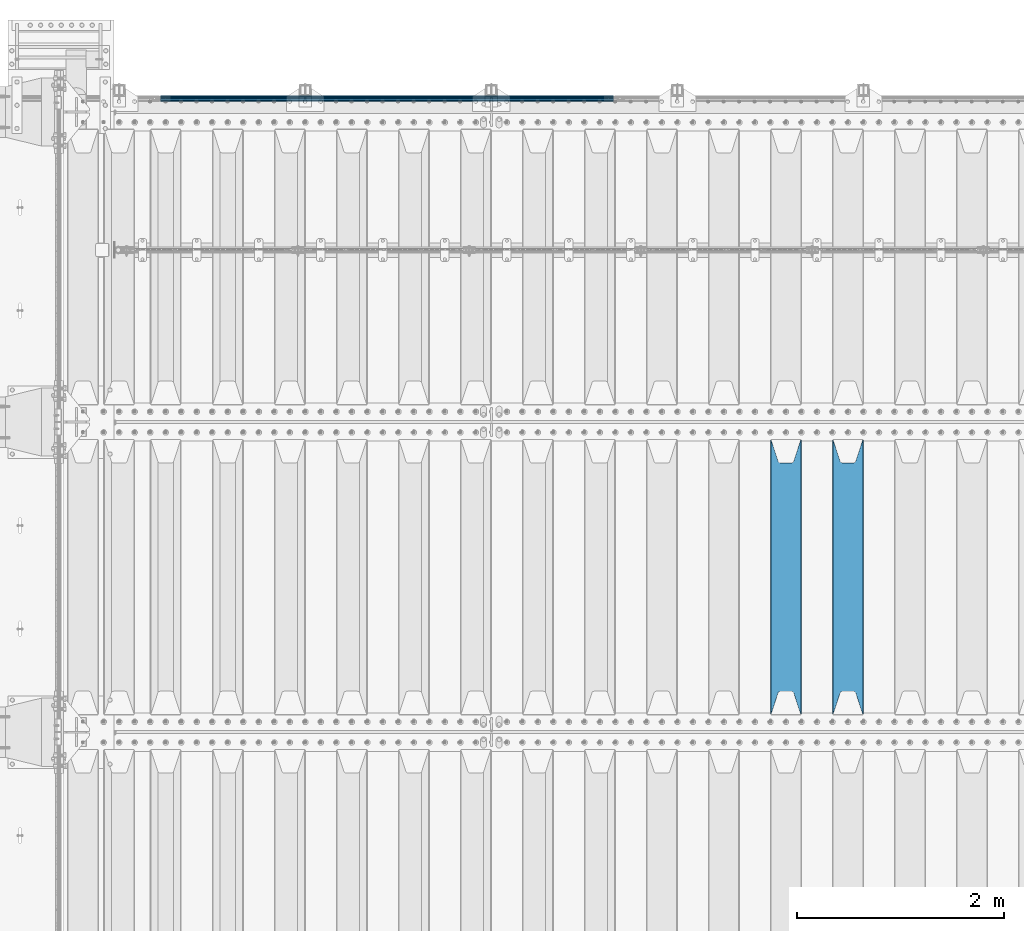
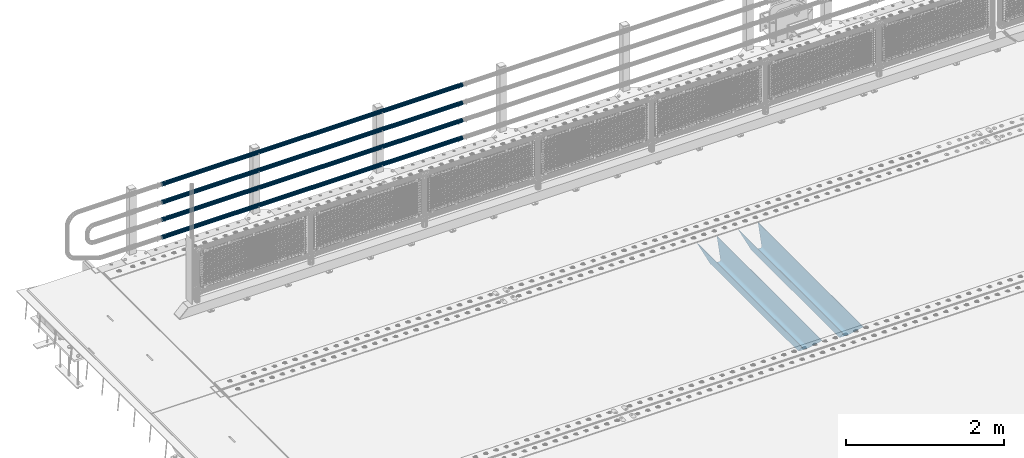
# One storey, part 119 of 240: 6 beams.
"""IFC2X3 building model written with IfcOpenShell, lengths in millimetres."""

from ifc_helpers import new_model, si_unit, frame, origin_with_axes, place, context, subcontext, project, spatial, faceted_brep, material, type_object, element, save


model = new_model("IFC2X3")

# Units and contexts
model_context = context("Model", 3, precision=1e-05, world=origin_with_axes())
body_context = subcontext(model_context, "Body", "Model", "MODEL_VIEW")
ifc_project = project(units=[si_unit("LENGTHUNIT", "METRE", prefix="MILLI"), si_unit("AREAUNIT", "SQUARE_METRE"), si_unit("VOLUMEUNIT", "CUBIC_METRE"), si_unit("MASSUNIT", "GRAM", prefix="KILO"), si_unit("TIMEUNIT", "SECOND"), si_unit("PLANEANGLEUNIT", "RADIAN"), si_unit("SOLIDANGLEUNIT", "STERADIAN"), si_unit("THERMODYNAMICTEMPERATUREUNIT", "DEGREE_CELSIUS"), si_unit("LUMINOUSINTENSITYUNIT", "LUMEN")], contexts=[model_context])

# Site, building, storey
site_placement = place(None, origin_with_axes())
site = spatial("IfcSite", under=ifc_project, at=site_placement, CompositionType="ELEMENT")
building_placement = place(site_placement, origin_with_axes())
building = spatial("IfcBuilding", under=site, at=building_placement, Name="Standard", CompositionType="ELEMENT")
storey_placement = place(building_placement, origin_with_axes())
storey = spatial("IfcBuildingStorey", under=building, at=storey_placement, Name="Undefined", CompositionType="ELEMENT", Elevation=0.0)

# Beams
ifc_material_1 = material(Name="STEEL/S355N")
beam_type_1 = type_object("IfcBeamType", PredefinedType="NOTDEFINED")
beam_1_placement = place(storey_placement, frame((50050.0, 30175.0, -115.0), z_axis=(0.0, 0.0, 1.0), x_axis=(0.0, 1.0, 0.0)))
element("IfcBeam", 1, at=beam_1_placement, inside=storey, type_object=beam_type_1, material=ifc_material_1, context=body_context, shape_type="Brep", body=[
    faceted_brep([(0.0, 150.0, 115.0), (0.0, 143.690000000002, 115.0), (2650.00000000297, 143.690000000002, 115.0), (2650.00000000297, 150.0, 115.0), (2650.00000000297, 142.059565218406, 110.000000003094), (2650.00000000297, 148.369565218403, 110.000000003094), (2441.90079219209, -80.1103600731149, -98.0992078077845), (2437.7588105432, -77.5672621345584, -102.241189456673), (2434.06523489747, -74.4080125315522, -105.934765102404), (2430.9108609509, -70.7102721255724, -109.089139048974), (2428.37322971128, -66.5649389910031, -111.626770288588), (2426.51472138055, -62.0739139532889, -113.485278619323), (2425.38102192092, -57.3475956567636, -114.618978078955), (2424.99999999987, -52.5021667386536, -115.0), (2424.99999999987, 52.5021667386536, -115.0), (2425.38102192092, 57.3475956567636, -114.618978078955), (2426.51472138055, 62.0739139532889, -113.485278619323), (2428.37322971128, 66.5649389910031, -111.626770288588), (2430.9108609509, 70.7102721255724, -109.089139048974), (2434.06523489747, 74.4080125315522, -105.934765102404), (2437.7588105432, 77.5672621345584, -102.241189456673), (2441.90079219209, 80.1103600731149, -98.0992078077846), (2446.38936140512, 81.9747917625791, -93.6106385947584), (2448.2494850041, 76.2713538057287, -91.7505149957729), (2444.62967112263, 74.76777986261, -95.3703288772456), (2441.28936334127, 72.7168944282894, -98.710636658607), (2438.31067330439, 70.1691124903809, -101.689326695487), (2435.76682334748, 67.1870637758839, -104.233176652398), (2433.72034654134, 63.8440531834931, -106.279653458539), (2432.22154950042, 60.2222587982324, -107.778450499454), (2431.30727574265, 56.4107117849126, -108.692724257221), (2430.99999999987, 52.5031078186876, -109.0), (2430.99999999987, -52.5031078186876, -109.0), (2431.30727574265, -56.4107117849126, -108.692724257221), (2432.22154950042, -60.2222587982324, -107.778450499454), (2433.72034654134, -63.8440531834931, -106.279653458539), (2435.76682334748, -67.1870637758839, -104.233176652398), (2438.31067330439, -70.1691124903809, -101.689326695487), (2441.28936334127, -72.7168944282894, -98.7106366586071), (2444.62967112263, -74.76777986261, -95.3703288772457), (2448.2494850041, -76.2713538057287, -91.7505149957729), (2650.00000000297, -142.059565218406, 110.000000003094), (2650.00000000297, -148.369565218403, 110.000000003094), (2446.38936140512, -81.9747917625791, -93.6106385947584), (2650.00000000297, -143.690000000002, 115.0), (2650.00000000297, -150.0, 115.0), (0.0, -143.690000000002, 115.0), (0.0, -150.0, 115.0), (0.0, -148.369565218258, 110.000000002667), (203.610638597427, -81.9747917625791, -93.6106385947584), (208.09920781045, -80.1103600731149, -98.0992078077845), (212.241189459342, -77.5672621345584, -102.241189456673), (215.93476510507, -74.4080125315522, -105.934765102404), (219.089139051641, -70.7102721255724, -109.089139048974), (221.626770291256, -66.5649389910031, -111.626770288588), (223.485278621989, -62.0739139532889, -113.485278619323), (224.618978081624, -57.3475956567636, -114.618978078955), (225.000000002663, -52.5021667386536, -115.0), (225.000000002663, 52.5021667386536, -115.0), (224.618978081624, 57.3475956567636, -114.618978078955), (223.485278621989, 62.0739139532889, -113.485278619323), (221.626770291256, 66.5649389910031, -111.626770288588), (219.089139051641, 70.7102721255724, -109.089139048974), (215.93476510507, 74.4080125315522, -105.934765102404), (212.241189459342, 77.5672621345584, -102.241189456673), (208.09920781045, 80.1103600731149, -98.0992078077846), (203.610638597427, 81.9747917625791, -93.6106385947584), (0.0, 148.369565218258, 110.000000002667), (0.0, 142.05956521826, 110.000000002667), (201.750514998439, 76.2713538057287, -91.7505149957729), (205.370328879908, 74.76777986261, -95.3703288772456), (208.710636661275, 72.7168944282894, -98.710636658607), (211.689326698153, 70.1691124903809, -101.689326695487), (214.233176655063, 67.1870637758839, -104.233176652398), (216.279653461206, 63.8440531834931, -106.279653458539), (217.778450502123, 60.2222587982324, -107.778450499454), (218.692724259887, 56.4107117849126, -108.692724257221), (219.000000002667, 52.5031078186876, -109.0), (219.000000002667, -52.5031078186876, -109.0), (218.692724259887, -56.4107117849126, -108.692724257221), (217.778450502123, -60.2222587982324, -107.778450499454), (216.279653461206, -63.8440531834931, -106.279653458539), (214.233176655063, -67.1870637758839, -104.233176652398), (211.689326698153, -70.1691124903809, -101.689326695487), (208.710636661275, -72.7168944282894, -98.7106366586071), (205.370328879915, -74.76777986261, -95.3703288772457), (201.750514998439, -76.2713538057287, -91.7505149957729), (0.0, -142.05956521826, 110.000000002667)], [[[0, 1, 2, 3]], [[3, 2, 4, 5]], [[6, 7, 8, 9, 10, 11, 12, 13, 14, 15, 16, 17, 18, 19, 20, 21, 22, 5, 4, 23, 24, 25, 26, 27, 28, 29, 30, 31, 32, 33, 34, 35, 36, 37, 38, 39, 40, 41, 42, 43]], [[44, 45, 42, 41]], [[46, 47, 45, 44]], [[43, 42, 45, 47, 48, 49]], [[6, 43, 49, 50]], [[7, 6, 50, 51]], [[8, 7, 51, 52]], [[9, 8, 52, 53]], [[10, 9, 53, 54]], [[11, 10, 54, 55]], [[12, 11, 55, 56]], [[13, 12, 56, 57]], [[14, 13, 57, 58]], [[15, 14, 58, 59]], [[16, 15, 59, 60]], [[17, 16, 60, 61]], [[18, 17, 61, 62]], [[19, 18, 62, 63]], [[20, 19, 63, 64]], [[21, 20, 64, 65]], [[22, 21, 65, 66]], [[0, 3, 5, 22, 66, 67]], [[1, 0, 67, 68]], [[23, 4, 2, 1, 68, 69]], [[24, 23, 69, 70]], [[25, 24, 70, 71]], [[26, 25, 71, 72]], [[27, 26, 72, 73]], [[28, 27, 73, 74]], [[29, 28, 74, 75]], [[30, 29, 75, 76]], [[31, 30, 76, 77]], [[32, 31, 77, 78]], [[33, 32, 78, 79]], [[34, 33, 79, 80]], [[35, 34, 80, 81]], [[36, 35, 81, 82]], [[37, 36, 82, 83]], [[38, 37, 83, 84]], [[39, 38, 84, 85]], [[40, 39, 85, 86]], [[46, 44, 41, 40, 86, 87]], [[47, 46, 87, 48]], [[86, 85, 84, 83, 82, 81, 80, 79, 78, 77, 76, 75, 74, 73, 72, 71, 70, 69, 68, 67, 66, 65, 64, 63, 62, 61, 60, 59, 58, 57, 56, 55, 54, 53, 52, 51, 50, 49, 48, 87]]]),
])
beam_2_placement = place(storey_placement, frame((49450.0, 30175.0, -115.0), z_axis=(0.0, 0.0, 1.0), x_axis=(0.0, 1.0, 0.0)))
element("IfcBeam", 2, at=beam_2_placement, inside=storey, type_object=beam_type_1, material=ifc_material_1, context=body_context, shape_type="Brep", body=[
    faceted_brep([(0.0, 150.0, 115.0), (0.0, 143.690000000002, 115.0), (2650.00000000297, 143.690000000002, 115.0), (2650.00000000297, 150.0, 115.0), (2650.00000000297, 142.059565218406, 110.000000003094), (2650.00000000297, 148.369565218403, 110.000000003094), (2441.90079219209, -80.1103600731149, -98.0992078077845), (2437.7588105432, -77.5672621345584, -102.241189456673), (2434.06523489747, -74.4080125315522, -105.934765102404), (2430.9108609509, -70.7102721255724, -109.089139048974), (2428.37322971128, -66.5649389910031, -111.626770288588), (2426.51472138055, -62.0739139532889, -113.485278619323), (2425.38102192092, -57.3475956567636, -114.618978078955), (2424.99999999987, -52.5021667386536, -115.0), (2424.99999999987, 52.5021667386536, -115.0), (2425.38102192092, 57.3475956567636, -114.618978078955), (2426.51472138055, 62.0739139532889, -113.485278619323), (2428.37322971128, 66.5649389910031, -111.626770288588), (2430.9108609509, 70.7102721255724, -109.089139048974), (2434.06523489747, 74.4080125315522, -105.934765102404), (2437.7588105432, 77.5672621345584, -102.241189456673), (2441.90079219209, 80.1103600731149, -98.0992078077846), (2446.38936140512, 81.9747917625791, -93.6106385947584), (2448.2494850041, 76.2713538057287, -91.7505149957729), (2444.62967112263, 74.76777986261, -95.3703288772456), (2441.28936334127, 72.7168944282894, -98.710636658607), (2438.31067330439, 70.1691124903809, -101.689326695487), (2435.76682334748, 67.1870637758839, -104.233176652398), (2433.72034654134, 63.8440531834931, -106.279653458539), (2432.22154950042, 60.2222587982324, -107.778450499454), (2431.30727574265, 56.4107117849126, -108.692724257221), (2430.99999999987, 52.5031078186876, -109.0), (2430.99999999987, -52.5031078186876, -109.0), (2431.30727574265, -56.4107117849126, -108.692724257221), (2432.22154950042, -60.2222587982324, -107.778450499454), (2433.72034654134, -63.8440531834931, -106.279653458539), (2435.76682334748, -67.1870637758839, -104.233176652398), (2438.31067330439, -70.1691124903809, -101.689326695487), (2441.28936334127, -72.7168944282894, -98.7106366586071), (2444.62967112263, -74.76777986261, -95.3703288772457), (2448.2494850041, -76.2713538057287, -91.7505149957729), (2650.00000000297, -142.059565218406, 110.000000003094), (2650.00000000297, -148.369565218403, 110.000000003094), (2446.38936140512, -81.9747917625791, -93.6106385947584), (2650.00000000297, -143.690000000002, 115.0), (2650.00000000297, -150.0, 115.0), (0.0, -143.690000000002, 115.0), (0.0, -150.0, 115.0), (0.0, -148.369565218258, 110.000000002667), (203.610638597427, -81.9747917625791, -93.6106385947584), (208.09920781045, -80.1103600731149, -98.0992078077845), (212.241189459342, -77.5672621345584, -102.241189456673), (215.93476510507, -74.4080125315522, -105.934765102404), (219.089139051641, -70.7102721255724, -109.089139048974), (221.626770291256, -66.5649389910031, -111.626770288588), (223.485278621989, -62.0739139532889, -113.485278619323), (224.618978081624, -57.3475956567636, -114.618978078955), (225.000000002663, -52.5021667386536, -115.0), (225.000000002663, 52.5021667386536, -115.0), (224.618978081624, 57.3475956567636, -114.618978078955), (223.485278621989, 62.0739139532889, -113.485278619323), (221.626770291256, 66.5649389910031, -111.626770288588), (219.089139051641, 70.7102721255724, -109.089139048974), (215.93476510507, 74.4080125315522, -105.934765102404), (212.241189459342, 77.5672621345584, -102.241189456673), (208.09920781045, 80.1103600731149, -98.0992078077846), (203.610638597427, 81.9747917625791, -93.6106385947584), (0.0, 148.369565218258, 110.000000002667), (0.0, 142.05956521826, 110.000000002667), (201.750514998439, 76.2713538057287, -91.7505149957729), (205.370328879908, 74.76777986261, -95.3703288772456), (208.710636661275, 72.7168944282894, -98.710636658607), (211.689326698153, 70.1691124903809, -101.689326695487), (214.233176655063, 67.1870637758839, -104.233176652398), (216.279653461206, 63.8440531834931, -106.279653458539), (217.778450502123, 60.2222587982324, -107.778450499454), (218.692724259887, 56.4107117849126, -108.692724257221), (219.000000002667, 52.5031078186876, -109.0), (219.000000002667, -52.5031078186876, -109.0), (218.692724259887, -56.4107117849126, -108.692724257221), (217.778450502123, -60.2222587982324, -107.778450499454), (216.279653461206, -63.8440531834931, -106.279653458539), (214.233176655063, -67.1870637758839, -104.233176652398), (211.689326698153, -70.1691124903809, -101.689326695487), (208.710636661275, -72.7168944282894, -98.7106366586071), (205.370328879915, -74.76777986261, -95.3703288772457), (201.750514998439, -76.2713538057287, -91.7505149957729), (0.0, -142.05956521826, 110.000000002667)], [[[0, 1, 2, 3]], [[3, 2, 4, 5]], [[6, 7, 8, 9, 10, 11, 12, 13, 14, 15, 16, 17, 18, 19, 20, 21, 22, 5, 4, 23, 24, 25, 26, 27, 28, 29, 30, 31, 32, 33, 34, 35, 36, 37, 38, 39, 40, 41, 42, 43]], [[44, 45, 42, 41]], [[46, 47, 45, 44]], [[43, 42, 45, 47, 48, 49]], [[6, 43, 49, 50]], [[7, 6, 50, 51]], [[8, 7, 51, 52]], [[9, 8, 52, 53]], [[10, 9, 53, 54]], [[11, 10, 54, 55]], [[12, 11, 55, 56]], [[13, 12, 56, 57]], [[14, 13, 57, 58]], [[15, 14, 58, 59]], [[16, 15, 59, 60]], [[17, 16, 60, 61]], [[18, 17, 61, 62]], [[19, 18, 62, 63]], [[20, 19, 63, 64]], [[21, 20, 64, 65]], [[22, 21, 65, 66]], [[0, 3, 5, 22, 66, 67]], [[1, 0, 67, 68]], [[23, 4, 2, 1, 68, 69]], [[24, 23, 69, 70]], [[25, 24, 70, 71]], [[26, 25, 71, 72]], [[27, 26, 72, 73]], [[28, 27, 73, 74]], [[29, 28, 74, 75]], [[30, 29, 75, 76]], [[31, 30, 76, 77]], [[32, 31, 77, 78]], [[33, 32, 78, 79]], [[34, 33, 79, 80]], [[35, 34, 80, 81]], [[36, 35, 81, 82]], [[37, 36, 82, 83]], [[38, 37, 83, 84]], [[39, 38, 84, 85]], [[40, 39, 85, 86]], [[46, 44, 41, 40, 86, 87]], [[47, 46, 87, 48]], [[86, 85, 84, 83, 82, 81, 80, 79, 78, 77, 76, 75, 74, 73, 72, 71, 70, 69, 68, 67, 66, 65, 64, 63, 62, 61, 60, 59, 58, 57, 56, 55, 54, 53, 52, 51, 50, 49, 48, 87]]]),
])
ifc_material_2 = material()
beam_type_2 = type_object("IfcBeamType", PredefinedType="NOTDEFINED")
beam_3_placement = place(storey_placement, frame((47783.9999999999, 36129.8500000001, 149.849999999748), z_axis=(0.0, 0.0, -1.0), x_axis=(-1.0, 0.0, 0.0)))
element("IfcBeam", 3, at=beam_3_placement, inside=storey, type_object=beam_type_2, material=ifc_material_2, context=body_context, shape_type="Brep", body=[
    faceted_brep([(0.0, -26.5500000000029, 0.0), (0.0, -24.5290015881765, 10.1602451292931), (4384.00249699992, -24.5290015881765, 10.1602451292931), (4384.00249699992, -26.5500000000029, 0.0), (0.0, -18.7736850405054, 18.7736850405028), (4384.00249699992, -18.7736850405054, 18.7736850405028), (0.0, -10.1602451292929, 24.5290015881747), (4384.00249699992, -10.1602451292929, 24.5290015881747), (0.0, 0.0, 26.55), (4384.00249699992, 0.0, 26.55), (0.0, 10.1602451292929, 24.5290015881747), (4384.00249699992, 10.1602451292929, 24.5290015881747), (0.0, 18.7736850405054, 18.7736850405028), (4384.00249699992, 18.7736850405054, 18.7736850405028), (0.0, 24.5290015881765, 10.1602451292931), (4384.00249699992, 24.5290015881765, 10.1602451292931), (0.0, 26.5500000000029, 0.0), (4384.00249699992, 26.5500000000029, 0.0), (0.0, 24.5290015881765, -10.1602451292931), (4384.00249699992, 24.5290015881765, -10.1602451292931), (0.0, 18.7736850405054, -18.7736850405028), (4384.00249699992, 18.7736850405054, -18.7736850405028), (0.0, 10.1602451292929, -24.5290015881747), (4384.00249699992, 10.1602451292929, -24.5290015881747), (0.0, 0.0, -26.55), (4384.00249699992, 0.0, -26.55), (0.0, -10.1602451292929, -24.5290015881747), (4384.00249699992, -10.1602451292929, -24.5290015881747), (0.0, -18.7736850405054, -18.7736850405028), (4384.00249699992, -18.7736850405054, -18.7736850405028), (0.0, -24.5290015881765, -10.1602451292931), (4384.00249699992, -24.5290015881765, -10.1602451292931), (0.0, -30.1500000000015, 0.0), (0.0, -27.8549679052157, -11.5379054858058), (4384.00249699992, -27.8549679052157, -11.5379054858075), (4384.00249699992, -30.1500000000015, 0.0), (0.0, -21.3192694527752, -21.3192694527752), (4384.00249699992, -21.3192694527752, -21.3192694527744), (0.0, -11.5379054858058, -27.8549679052157), (4384.00249699992, -11.5379054858058, -27.8549679052153), (0.0, 0.0, -30.1500000000015), (4384.00249699992, 0.0, -30.15), (0.0, 11.5379054858058, -27.8549679052157), (4384.00249699992, 11.5379054858058, -27.8549679052153), (0.0, 21.3192694527752, -21.3192694527752), (4384.00249699992, 21.3192694527752, -21.3192694527744), (0.0, 27.8549679052157, -11.5379054858058), (4384.00249699992, 27.8549679052157, -11.5379054858074), (0.0, 30.1500000000015, 0.0), (4384.00249699992, 30.1500000000015, 0.0), (0.0, 27.8549679052157, 11.5379054858058), (4384.00249699992, 27.8549679052157, 11.5379054858075), (0.0, 21.3192694527752, 21.3192694527752), (4384.00249699992, 21.3192694527752, 21.3192694527744), (0.0, 11.5379054858058, 27.8549679052157), (4384.00249699992, 11.5379054858058, 27.8549679052153), (0.0, 0.0, 30.1500000000015), (4384.00249699992, 0.0, 30.15), (0.0, -11.5379054858058, 27.8549679052157), (4384.00249699992, -11.5379054858058, 27.8549679052153), (0.0, -21.3192694527752, 21.3192694527752), (4384.00249699992, -21.3192694527752, 21.3192694527744), (0.0, -27.8549679052157, 11.5379054858058), (4384.00249699992, -27.8549679052157, 11.5379054858075)], [[[0, 1, 2, 3]], [[1, 4, 5, 2]], [[4, 6, 7, 5]], [[6, 8, 9, 7]], [[8, 10, 11, 9]], [[10, 12, 13, 11]], [[12, 14, 15, 13]], [[14, 16, 17, 15]], [[16, 18, 19, 17]], [[18, 20, 21, 19]], [[20, 22, 23, 21]], [[22, 24, 25, 23]], [[24, 26, 27, 25]], [[26, 28, 29, 27]], [[28, 30, 31, 29]], [[30, 0, 3, 31]], [[32, 33, 34, 35]], [[33, 36, 37, 34]], [[36, 38, 39, 37]], [[38, 40, 41, 39]], [[40, 42, 43, 41]], [[42, 44, 45, 43]], [[44, 46, 47, 45]], [[46, 48, 49, 47]], [[48, 50, 51, 49]], [[50, 52, 53, 51]], [[52, 54, 55, 53]], [[54, 56, 57, 55]], [[56, 58, 59, 57]], [[58, 60, 61, 59]], [[60, 62, 63, 61]], [[62, 32, 35, 63]], [[37, 39, 41, 43, 45, 47, 49, 51, 53, 55, 57, 59, 61, 63, 35, 34], [5, 7, 9, 11, 13, 15, 17, 19, 21, 23, 25, 27, 29, 31, 3, 2]], [[62, 60, 58, 56, 54, 52, 50, 48, 46, 44, 42, 40, 38, 36, 33, 32], [30, 28, 26, 24, 22, 20, 18, 16, 14, 12, 10, 8, 6, 4, 1, 0]]]),
])
beam_4_placement = place(storey_placement, frame((47783.9999999999, 36129.8500000001, 420.149999999748), z_axis=(0.0, 0.0, -1.0), x_axis=(-1.0, 0.0, 0.0)))
element("IfcBeam", 4, at=beam_4_placement, inside=storey, type_object=beam_type_2, material=ifc_material_2, context=body_context, shape_type="Brep", body=[
    faceted_brep([(0.0, -26.5500000000029, 0.0), (0.0, -24.5290015881765, 10.1602451292931), (4384.00249699992, -24.5290015881765, 10.1602451292931), (4384.00249699992, -26.5500000000029, 0.0), (0.0, -18.7736850405054, 18.7736850405028), (4384.00249699992, -18.7736850405054, 18.7736850405028), (0.0, -10.1602451292929, 24.5290015881747), (4384.00249699992, -10.1602451292929, 24.5290015881747), (0.0, 0.0, 26.55), (4384.00249699992, 0.0, 26.55), (0.0, 10.1602451292929, 24.5290015881747), (4384.00249699992, 10.1602451292929, 24.5290015881747), (0.0, 18.7736850405054, 18.7736850405028), (4384.00249699992, 18.7736850405054, 18.7736850405028), (0.0, 24.5290015881765, 10.1602451292931), (4384.00249699992, 24.5290015881765, 10.1602451292931), (0.0, 26.5500000000029, 0.0), (4384.00249699992, 26.5500000000029, 0.0), (0.0, 24.5290015881765, -10.1602451292931), (4384.00249699992, 24.5290015881765, -10.1602451292931), (0.0, 18.7736850405054, -18.7736850405028), (4384.00249699992, 18.7736850405054, -18.7736850405028), (0.0, 10.1602451292929, -24.5290015881747), (4384.00249699992, 10.1602451292929, -24.5290015881747), (0.0, 0.0, -26.55), (4384.00249699992, 0.0, -26.55), (0.0, -10.1602451292929, -24.5290015881747), (4384.00249699992, -10.1602451292929, -24.5290015881747), (0.0, -18.7736850405054, -18.7736850405028), (4384.00249699992, -18.7736850405054, -18.7736850405028), (0.0, -24.5290015881765, -10.1602451292931), (4384.00249699992, -24.5290015881765, -10.1602451292931), (0.0, -30.1500000000015, 0.0), (0.0, -27.8549679052157, -11.5379054858058), (4384.00249699992, -27.8549679052157, -11.5379054858075), (4384.00249699992, -30.1500000000015, 0.0), (0.0, -21.3192694527752, -21.3192694527752), (4384.00249699992, -21.3192694527752, -21.3192694527744), (0.0, -11.5379054858058, -27.8549679052157), (4384.00249699992, -11.5379054858058, -27.8549679052153), (0.0, 0.0, -30.1500000000015), (4384.00249699992, 0.0, -30.15), (0.0, 11.5379054858058, -27.8549679052157), (4384.00249699992, 11.5379054858058, -27.8549679052153), (0.0, 21.3192694527752, -21.3192694527752), (4384.00249699992, 21.3192694527752, -21.3192694527744), (0.0, 27.8549679052157, -11.5379054858058), (4384.00249699992, 27.8549679052157, -11.5379054858074), (0.0, 30.1500000000015, 0.0), (4384.00249699992, 30.1500000000015, 0.0), (0.0, 27.8549679052157, 11.5379054858058), (4384.00249699992, 27.8549679052157, 11.5379054858075), (0.0, 21.3192694527752, 21.3192694527752), (4384.00249699992, 21.3192694527752, 21.3192694527744), (0.0, 11.5379054858058, 27.8549679052157), (4384.00249699992, 11.5379054858058, 27.8549679052153), (0.0, 0.0, 30.1500000000015), (4384.00249699992, 0.0, 30.15), (0.0, -11.5379054858058, 27.8549679052157), (4384.00249699992, -11.5379054858058, 27.8549679052153), (0.0, -21.3192694527752, 21.3192694527752), (4384.00249699992, -21.3192694527752, 21.3192694527744), (0.0, -27.8549679052157, 11.5379054858058), (4384.00249699992, -27.8549679052157, 11.5379054858075)], [[[0, 1, 2, 3]], [[1, 4, 5, 2]], [[4, 6, 7, 5]], [[6, 8, 9, 7]], [[8, 10, 11, 9]], [[10, 12, 13, 11]], [[12, 14, 15, 13]], [[14, 16, 17, 15]], [[16, 18, 19, 17]], [[18, 20, 21, 19]], [[20, 22, 23, 21]], [[22, 24, 25, 23]], [[24, 26, 27, 25]], [[26, 28, 29, 27]], [[28, 30, 31, 29]], [[30, 0, 3, 31]], [[32, 33, 34, 35]], [[33, 36, 37, 34]], [[36, 38, 39, 37]], [[38, 40, 41, 39]], [[40, 42, 43, 41]], [[42, 44, 45, 43]], [[44, 46, 47, 45]], [[46, 48, 49, 47]], [[48, 50, 51, 49]], [[50, 52, 53, 51]], [[52, 54, 55, 53]], [[54, 56, 57, 55]], [[56, 58, 59, 57]], [[58, 60, 61, 59]], [[60, 62, 63, 61]], [[62, 32, 35, 63]], [[37, 39, 41, 43, 45, 47, 49, 51, 53, 55, 57, 59, 61, 63, 35, 34], [5, 7, 9, 11, 13, 15, 17, 19, 21, 23, 25, 27, 29, 31, 3, 2]], [[62, 60, 58, 56, 54, 52, 50, 48, 46, 44, 42, 40, 38, 36, 33, 32], [30, 28, 26, 24, 22, 20, 18, 16, 14, 12, 10, 8, 6, 4, 1, 0]]]),
])
beam_5_placement = place(storey_placement, frame((47783.9999999999, 36129.8500000001, 969.849999999748), z_axis=(0.0, 0.0, -1.0), x_axis=(-1.0, 0.0, 0.0)))
element("IfcBeam", 5, at=beam_5_placement, inside=storey, type_object=beam_type_2, material=ifc_material_2, context=body_context, shape_type="Brep", body=[
    faceted_brep([(0.0, -26.5500000000029, 0.0), (0.0, -24.5290015881765, 10.1602451292931), (4384.00249699992, -24.5290015881765, 10.1602451292931), (4384.00249699992, -26.5500000000029, 0.0), (0.0, -18.7736850405054, 18.7736850405028), (4384.00249699992, -18.7736850405054, 18.7736850405028), (0.0, -10.1602451292929, 24.5290015881747), (4384.00249699992, -10.1602451292929, 24.5290015881747), (0.0, 0.0, 26.55), (4384.00249699992, 0.0, 26.55), (0.0, 10.1602451292929, 24.5290015881747), (4384.00249699992, 10.1602451292929, 24.5290015881747), (0.0, 18.7736850405054, 18.7736850405028), (4384.00249699992, 18.7736850405054, 18.7736850405028), (0.0, 24.5290015881765, 10.1602451292931), (4384.00249699992, 24.5290015881765, 10.1602451292931), (0.0, 26.5500000000029, 0.0), (4384.00249699992, 26.5500000000029, 0.0), (0.0, 24.5290015881765, -10.1602451292931), (4384.00249699992, 24.5290015881765, -10.1602451292931), (0.0, 18.7736850405054, -18.7736850405028), (4384.00249699992, 18.7736850405054, -18.7736850405028), (0.0, 10.1602451292929, -24.5290015881747), (4384.00249699992, 10.1602451292929, -24.5290015881747), (0.0, 0.0, -26.55), (4384.00249699992, 0.0, -26.55), (0.0, -10.1602451292929, -24.5290015881747), (4384.00249699992, -10.1602451292929, -24.5290015881747), (0.0, -18.7736850405054, -18.7736850405028), (4384.00249699992, -18.7736850405054, -18.7736850405028), (0.0, -24.5290015881765, -10.1602451292931), (4384.00249699992, -24.5290015881765, -10.1602451292931), (0.0, -30.1500000000015, 0.0), (0.0, -27.8549679052157, -11.5379054858058), (4384.00249699992, -27.8549679052157, -11.5379054858075), (4384.00249699992, -30.1500000000015, 0.0), (0.0, -21.3192694527752, -21.3192694527752), (4384.00249699992, -21.3192694527752, -21.3192694527744), (0.0, -11.5379054858058, -27.8549679052157), (4384.00249699992, -11.5379054858058, -27.8549679052153), (0.0, 0.0, -30.1500000000015), (4384.00249699992, 0.0, -30.15), (0.0, 11.5379054858058, -27.8549679052157), (4384.00249699992, 11.5379054858058, -27.8549679052153), (0.0, 21.3192694527752, -21.3192694527752), (4384.00249699992, 21.3192694527752, -21.3192694527744), (0.0, 27.8549679052157, -11.5379054858058), (4384.00249699992, 27.8549679052157, -11.5379054858074), (0.0, 30.1500000000015, 0.0), (4384.00249699992, 30.1500000000015, 0.0), (0.0, 27.8549679052157, 11.5379054858058), (4384.00249699992, 27.8549679052157, 11.5379054858075), (0.0, 21.3192694527752, 21.3192694527752), (4384.00249699992, 21.3192694527752, 21.3192694527744), (0.0, 11.5379054858058, 27.8549679052157), (4384.00249699992, 11.5379054858058, 27.8549679052153), (0.0, 0.0, 30.1500000000015), (4384.00249699992, 0.0, 30.15), (0.0, -11.5379054858058, 27.8549679052157), (4384.00249699992, -11.5379054858058, 27.8549679052153), (0.0, -21.3192694527752, 21.3192694527752), (4384.00249699992, -21.3192694527752, 21.3192694527744), (0.0, -27.8549679052157, 11.5379054858058), (4384.00249699992, -27.8549679052157, 11.5379054858075)], [[[0, 1, 2, 3]], [[1, 4, 5, 2]], [[4, 6, 7, 5]], [[6, 8, 9, 7]], [[8, 10, 11, 9]], [[10, 12, 13, 11]], [[12, 14, 15, 13]], [[14, 16, 17, 15]], [[16, 18, 19, 17]], [[18, 20, 21, 19]], [[20, 22, 23, 21]], [[22, 24, 25, 23]], [[24, 26, 27, 25]], [[26, 28, 29, 27]], [[28, 30, 31, 29]], [[30, 0, 3, 31]], [[32, 33, 34, 35]], [[33, 36, 37, 34]], [[36, 38, 39, 37]], [[38, 40, 41, 39]], [[40, 42, 43, 41]], [[42, 44, 45, 43]], [[44, 46, 47, 45]], [[46, 48, 49, 47]], [[48, 50, 51, 49]], [[50, 52, 53, 51]], [[52, 54, 55, 53]], [[54, 56, 57, 55]], [[56, 58, 59, 57]], [[58, 60, 61, 59]], [[60, 62, 63, 61]], [[62, 32, 35, 63]], [[37, 39, 41, 43, 45, 47, 49, 51, 53, 55, 57, 59, 61, 63, 35, 34], [5, 7, 9, 11, 13, 15, 17, 19, 21, 23, 25, 27, 29, 31, 3, 2]], [[62, 60, 58, 56, 54, 52, 50, 48, 46, 44, 42, 40, 38, 36, 33, 32], [30, 28, 26, 24, 22, 20, 18, 16, 14, 12, 10, 8, 6, 4, 1, 0]]]),
])
beam_6_placement = place(storey_placement, frame((47783.9999999999, 36129.8500000001, 689.849999999748), z_axis=(0.0, 0.0, -1.0), x_axis=(-1.0, 0.0, 0.0)))
element("IfcBeam", 6, at=beam_6_placement, inside=storey, type_object=beam_type_2, material=ifc_material_2, context=body_context, shape_type="Brep", body=[
    faceted_brep([(0.0, -26.5500000000029, 0.0), (0.0, -24.5290015881765, 10.1602451292931), (4384.00249699992, -24.5290015881765, 10.1602451292931), (4384.00249699992, -26.5500000000029, 0.0), (0.0, -18.7736850405054, 18.7736850405028), (4384.00249699992, -18.7736850405054, 18.7736850405028), (0.0, -10.1602451292929, 24.5290015881747), (4384.00249699992, -10.1602451292929, 24.5290015881747), (0.0, 0.0, 26.55), (4384.00249699992, 0.0, 26.55), (0.0, 10.1602451292929, 24.5290015881747), (4384.00249699992, 10.1602451292929, 24.5290015881747), (0.0, 18.7736850405054, 18.7736850405028), (4384.00249699992, 18.7736850405054, 18.7736850405028), (0.0, 24.5290015881765, 10.1602451292931), (4384.00249699992, 24.5290015881765, 10.1602451292931), (0.0, 26.5500000000029, 0.0), (4384.00249699992, 26.5500000000029, 0.0), (0.0, 24.5290015881765, -10.1602451292931), (4384.00249699992, 24.5290015881765, -10.1602451292931), (0.0, 18.7736850405054, -18.7736850405028), (4384.00249699992, 18.7736850405054, -18.7736850405028), (0.0, 10.1602451292929, -24.5290015881747), (4384.00249699992, 10.1602451292929, -24.5290015881747), (0.0, 0.0, -26.55), (4384.00249699992, 0.0, -26.55), (0.0, -10.1602451292929, -24.5290015881747), (4384.00249699992, -10.1602451292929, -24.5290015881747), (0.0, -18.7736850405054, -18.7736850405028), (4384.00249699992, -18.7736850405054, -18.7736850405028), (0.0, -24.5290015881765, -10.1602451292931), (4384.00249699992, -24.5290015881765, -10.1602451292931), (0.0, -30.1500000000015, 0.0), (0.0, -27.8549679052157, -11.5379054858058), (4384.00249699992, -27.8549679052157, -11.5379054858075), (4384.00249699992, -30.1500000000015, 0.0), (0.0, -21.3192694527752, -21.3192694527752), (4384.00249699992, -21.3192694527752, -21.3192694527744), (0.0, -11.5379054858058, -27.8549679052157), (4384.00249699992, -11.5379054858058, -27.8549679052153), (0.0, 0.0, -30.1500000000015), (4384.00249699992, 0.0, -30.15), (0.0, 11.5379054858058, -27.8549679052157), (4384.00249699992, 11.5379054858058, -27.8549679052153), (0.0, 21.3192694527752, -21.3192694527752), (4384.00249699992, 21.3192694527752, -21.3192694527744), (0.0, 27.8549679052157, -11.5379054858058), (4384.00249699992, 27.8549679052157, -11.5379054858074), (0.0, 30.1500000000015, 0.0), (4384.00249699992, 30.1500000000015, 0.0), (0.0, 27.8549679052157, 11.5379054858058), (4384.00249699992, 27.8549679052157, 11.5379054858075), (0.0, 21.3192694527752, 21.3192694527752), (4384.00249699992, 21.3192694527752, 21.3192694527744), (0.0, 11.5379054858058, 27.8549679052157), (4384.00249699992, 11.5379054858058, 27.8549679052153), (0.0, 0.0, 30.1500000000015), (4384.00249699992, 0.0, 30.15), (0.0, -11.5379054858058, 27.8549679052157), (4384.00249699992, -11.5379054858058, 27.8549679052153), (0.0, -21.3192694527752, 21.3192694527752), (4384.00249699992, -21.3192694527752, 21.3192694527744), (0.0, -27.8549679052157, 11.5379054858058), (4384.00249699992, -27.8549679052157, 11.5379054858075)], [[[0, 1, 2, 3]], [[1, 4, 5, 2]], [[4, 6, 7, 5]], [[6, 8, 9, 7]], [[8, 10, 11, 9]], [[10, 12, 13, 11]], [[12, 14, 15, 13]], [[14, 16, 17, 15]], [[16, 18, 19, 17]], [[18, 20, 21, 19]], [[20, 22, 23, 21]], [[22, 24, 25, 23]], [[24, 26, 27, 25]], [[26, 28, 29, 27]], [[28, 30, 31, 29]], [[30, 0, 3, 31]], [[32, 33, 34, 35]], [[33, 36, 37, 34]], [[36, 38, 39, 37]], [[38, 40, 41, 39]], [[40, 42, 43, 41]], [[42, 44, 45, 43]], [[44, 46, 47, 45]], [[46, 48, 49, 47]], [[48, 50, 51, 49]], [[50, 52, 53, 51]], [[52, 54, 55, 53]], [[54, 56, 57, 55]], [[56, 58, 59, 57]], [[58, 60, 61, 59]], [[60, 62, 63, 61]], [[62, 32, 35, 63]], [[37, 39, 41, 43, 45, 47, 49, 51, 53, 55, 57, 59, 61, 63, 35, 34], [5, 7, 9, 11, 13, 15, 17, 19, 21, 23, 25, 27, 29, 31, 3, 2]], [[62, 60, 58, 56, 54, 52, 50, 48, 46, 44, 42, 40, 38, 36, 33, 32], [30, 28, 26, 24, 22, 20, 18, 16, 14, 12, 10, 8, 6, 4, 1, 0]]]),
])

save(model, "model.ifc")
